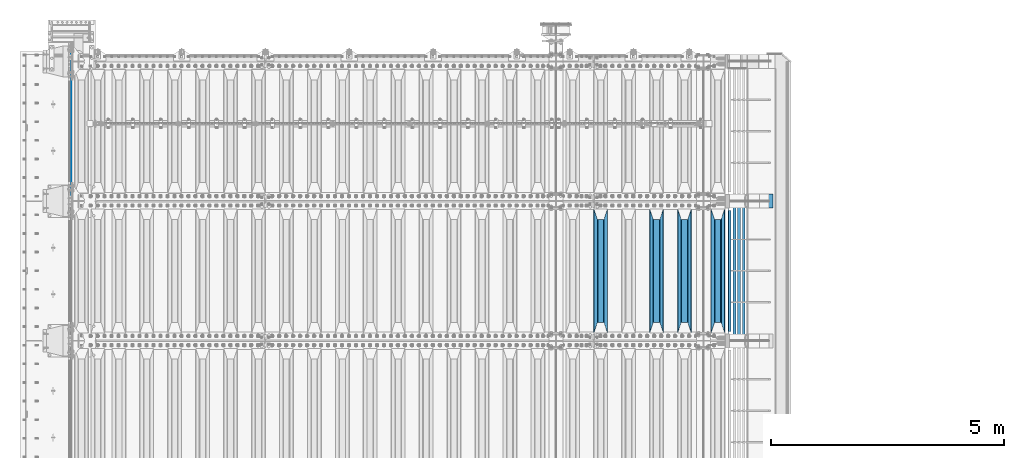
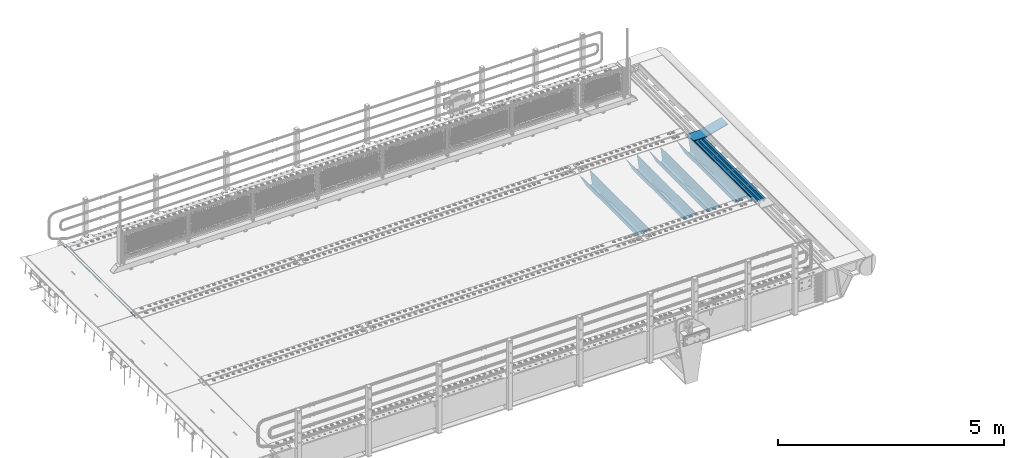
# One storey, part 107 of 219: 10 beams.
"""IFC2X3 building model written with IfcOpenShell, lengths in millimetres."""

from ifc_helpers import new_model, si_unit, frame, origin_with_axes, place, context, subcontext, project, spatial, faceted_brep, material, type_object, element, save


model = new_model("IFC2X3")

# Units and contexts
model_context = context("Model", 3, precision=1e-05, world=origin_with_axes())
body_context = subcontext(model_context, "Body", "Model", "MODEL_VIEW")
ifc_project = project(units=[si_unit("LENGTHUNIT", "METRE", prefix="MILLI"), si_unit("AREAUNIT", "SQUARE_METRE"), si_unit("VOLUMEUNIT", "CUBIC_METRE"), si_unit("MASSUNIT", "GRAM", prefix="KILO"), si_unit("TIMEUNIT", "SECOND"), si_unit("PLANEANGLEUNIT", "RADIAN"), si_unit("SOLIDANGLEUNIT", "STERADIAN"), si_unit("THERMODYNAMICTEMPERATUREUNIT", "DEGREE_CELSIUS"), si_unit("LUMINOUSINTENSITYUNIT", "LUMEN")], contexts=[model_context])

# Site, building, storey
site_placement = place(None, origin_with_axes())
site = spatial("IfcSite", under=ifc_project, at=site_placement, CompositionType="ELEMENT")
building_placement = place(site_placement, origin_with_axes())
building = spatial("IfcBuilding", under=site, at=building_placement, Name="Standard", CompositionType="ELEMENT")
storey_placement = place(building_placement, origin_with_axes())
storey = spatial("IfcBuildingStorey", under=building, at=storey_placement, Name="Undefined", CompositionType="ELEMENT", Elevation=0.0)

# Beams
ifc_material_1 = material(Name="STEEL/S355N")
beam_type_1 = type_object("IfcBeamType", Name="D20", PredefinedType="NOTDEFINED")
beam_1_placement = place(storey_placement, frame((-35.0, 30004.9999999999, -25.9999999971316), z_axis=(0.0, 0.0, 1.0), x_axis=(0.0, 1.0, 0.0)))
element("IfcBeam", 1, at=beam_1_placement, inside=storey, type_object=beam_type_1, material=ifc_material_1, ObjectType="D20", context=body_context, shape_type="Brep", body=[
    faceted_brep([(0.0, -10.0, 0.0), (0.0, -7.07106781186667, -7.07106781186548), (3145.00000000001, -7.07106781186548, -7.07106781186548), (3145.00000000001, -10.0, 0.0), (0.0, 0.0, -10.0), (3145.00000000001, 0.0, -10.0), (0.0, 7.07106781186667, -7.07106781186548), (3145.00000000001, 7.07106781186548, -7.07106781186547), (0.0, 10.0, 0.0), (3145.00000000001, 10.0, 0.0), (0.0, 7.07106781186667, 7.07106781186548), (3145.00000000001, 7.07106781186548, 7.07106781186548), (0.0, 0.0, 10.0), (3145.00000000001, 0.0, 10.0), (0.0, -7.07106781186667, 7.07106781186548), (3145.00000000001, -7.07106781186548, 7.07106781186548)], [[[0, 1, 2, 3]], [[1, 4, 5, 2]], [[4, 6, 7, 5]], [[6, 8, 9, 7]], [[8, 10, 11, 9]], [[10, 12, 13, 11]], [[12, 14, 15, 13]], [[14, 0, 3, 15]], [[5, 7, 9, 11, 13, 15, 3, 2]], [[14, 12, 10, 8, 6, 4, 1, 0]]]),
])
beam_type_2 = type_object("IfcBeamType", PredefinedType="NOTDEFINED")
beam_2_placement = place(storey_placement, frame((13867.0, 27175.0, -115.0), z_axis=(0.0, 0.0, 1.0), x_axis=(0.0, 1.0, 0.0)))
element("IfcBeam", 2, at=beam_2_placement, inside=storey, type_object=beam_type_2, material=ifc_material_1, context=body_context, shape_type="Brep", body=[
    faceted_brep([(0.0, 150.0, 115.0), (0.0, 143.690000000001, 115.0), (2650.00000000297, 143.690000000001, 115.0), (2650.00000000297, 150.0, 115.0), (2650.00000000297, 142.0595652184, 110.000000003094), (2650.00000000297, 148.3695652184, 110.000000003094), (2441.90079219209, -80.110360073113, -98.0992078077845), (2437.7588105432, -77.5672621345566, -102.241189456673), (2434.06523489747, -74.4080125315541, -105.934765102404), (2430.9108609509, -70.7102721255742, -109.089139048974), (2428.37322971128, -66.5649389910068, -111.626770288588), (2426.51472138055, -62.0739139532889, -113.485278619323), (2425.38102192092, -57.3475956567672, -114.618978078955), (2424.99999999988, -52.5021667386536, -115.0), (2424.99999999988, 52.5021667386536, -115.0), (2425.38102192092, 57.3475956567672, -114.618978078955), (2426.51472138055, 62.0739139532889, -113.485278619323), (2428.37322971128, 66.5649389910068, -111.626770288588), (2430.9108609509, 70.7102721255742, -109.089139048974), (2434.06523489747, 74.4080125315541, -105.934765102404), (2437.7588105432, 77.5672621345566, -102.241189456673), (2441.90079219209, 80.110360073113, -98.0992078077846), (2446.38936140512, 81.9747917625791, -93.6106385947584), (2448.2494850041, 76.2713538057269, -91.7505149957729), (2444.62967112263, 74.7677798626082, -95.3703288772456), (2441.28936334127, 72.7168944282894, -98.710636658607), (2438.31067330439, 70.1691124903828, -101.689326695487), (2435.76682334748, 67.1870637758839, -104.233176652398), (2433.72034654134, 63.8440531834913, -106.279653458539), (2432.22154950042, 60.2222587982342, -107.778450499454), (2431.30727574265, 56.4107117849107, -108.692724257221), (2430.99999999987, 52.5031078186894, -109.0), (2430.99999999987, -52.5031078186894, -109.0), (2431.30727574265, -56.4107117849107, -108.692724257221), (2432.22154950042, -60.2222587982342, -107.778450499454), (2433.72034654134, -63.8440531834913, -106.279653458539), (2435.76682334748, -67.1870637758839, -104.233176652398), (2438.31067330439, -70.1691124903828, -101.689326695487), (2441.28936334127, -72.7168944282894, -98.7106366586071), (2444.62967112263, -74.7677798626082, -95.3703288772457), (2448.2494850041, -76.2713538057269, -91.7505149957729), (2650.00000000297, -142.0595652184, 110.000000003094), (2650.00000000297, -148.3695652184, 110.000000003094), (2446.38936140512, -81.9747917625791, -93.6106385947584), (2650.00000000297, -143.690000000001, 115.0), (2650.00000000297, -150.0, 115.0), (0.0, -143.690000000001, 115.0), (0.0, -150.0, 115.0), (0.0, -148.369565218261, 110.000000002667), (203.610638597427, -81.9747917625791, -93.6106385947584), (208.09920781045, -80.110360073113, -98.0992078077845), (212.241189459342, -77.5672621345566, -102.241189456673), (215.93476510507, -74.4080125315541, -105.934765102404), (219.089139051641, -70.7102721255742, -109.089139048974), (221.626770291256, -66.5649389910068, -111.626770288588), (223.485278621989, -62.0739139532889, -113.485278619323), (224.618978081624, -57.3475956567672, -114.618978078955), (225.000000002663, -52.5021667386536, -115.0), (225.000000002663, 52.5021667386536, -115.0), (224.618978081624, 57.3475956567672, -114.618978078955), (223.485278621989, 62.0739139532889, -113.485278619323), (221.626770291256, 66.5649389910068, -111.626770288588), (219.089139051641, 70.7102721255742, -109.089139048974), (215.93476510507, 74.4080125315541, -105.934765102404), (212.241189459342, 77.5672621345566, -102.241189456673), (208.09920781045, 80.110360073113, -98.0992078077846), (203.610638597427, 81.9747917625791, -93.6106385947584), (0.0, 148.369565218261, 110.000000002667), (0.0, 142.059565218262, 110.000000002667), (201.750514998439, 76.2713538057269, -91.7505149957729), (205.370328879915, 74.7677798626082, -95.3703288772456), (208.710636661275, 72.7168944282894, -98.710636658607), (211.689326698157, 70.1691124903828, -101.689326695487), (214.233176655063, 67.1870637758839, -104.233176652398), (216.279653461206, 63.8440531834913, -106.279653458539), (217.778450502123, 60.2222587982342, -107.778450499454), (218.69272425989, 56.4107117849107, -108.692724257221), (219.00000000267, 52.5031078186894, -109.0), (219.00000000267, -52.5031078186894, -109.0), (218.69272425989, -56.4107117849107, -108.692724257221), (217.778450502123, -60.2222587982342, -107.778450499454), (216.279653461206, -63.8440531834913, -106.279653458539), (214.233176655063, -67.1870637758839, -104.233176652398), (211.689326698157, -70.1691124903828, -101.689326695487), (208.710636661275, -72.7168944282894, -98.7106366586071), (205.370328879915, -74.7677798626082, -95.3703288772457), (201.750514998439, -76.2713538057269, -91.7505149957729), (0.0, -142.059565218262, 110.000000002667)], [[[0, 1, 2, 3]], [[3, 2, 4, 5]], [[6, 7, 8, 9, 10, 11, 12, 13, 14, 15, 16, 17, 18, 19, 20, 21, 22, 5, 4, 23, 24, 25, 26, 27, 28, 29, 30, 31, 32, 33, 34, 35, 36, 37, 38, 39, 40, 41, 42, 43]], [[44, 45, 42, 41]], [[46, 47, 45, 44]], [[43, 42, 45, 47, 48, 49]], [[6, 43, 49, 50]], [[7, 6, 50, 51]], [[8, 7, 51, 52]], [[9, 8, 52, 53]], [[10, 9, 53, 54]], [[11, 10, 54, 55]], [[12, 11, 55, 56]], [[13, 12, 56, 57]], [[14, 13, 57, 58]], [[15, 14, 58, 59]], [[16, 15, 59, 60]], [[17, 16, 60, 61]], [[18, 17, 61, 62]], [[19, 18, 62, 63]], [[20, 19, 63, 64]], [[21, 20, 64, 65]], [[22, 21, 65, 66]], [[0, 3, 5, 22, 66, 67]], [[1, 0, 67, 68]], [[23, 4, 2, 1, 68, 69]], [[24, 23, 69, 70]], [[25, 24, 70, 71]], [[26, 25, 71, 72]], [[27, 26, 72, 73]], [[28, 27, 73, 74]], [[29, 28, 74, 75]], [[30, 29, 75, 76]], [[31, 30, 76, 77]], [[32, 31, 77, 78]], [[33, 32, 78, 79]], [[34, 33, 79, 80]], [[35, 34, 80, 81]], [[36, 35, 81, 82]], [[37, 36, 82, 83]], [[38, 37, 83, 84]], [[39, 38, 84, 85]], [[40, 39, 85, 86]], [[46, 44, 41, 40, 86, 87]], [[47, 46, 87, 48]], [[86, 85, 84, 83, 82, 81, 80, 79, 78, 77, 76, 75, 74, 73, 72, 71, 70, 69, 68, 67, 66, 65, 64, 63, 62, 61, 60, 59, 58, 57, 56, 55, 54, 53, 52, 51, 50, 49, 48, 87]]]),
])
beam_3_placement = place(storey_placement, frame((13150.0, 27175.0, -115.0), z_axis=(0.0, 0.0, 1.0), x_axis=(0.0, 1.0, 0.0)))
element("IfcBeam", 3, at=beam_3_placement, inside=storey, type_object=beam_type_2, material=ifc_material_1, context=body_context, shape_type="Brep", body=[
    faceted_brep([(0.0, 150.0, 115.0), (0.0, 143.690000000001, 115.0), (2650.00000000297, 143.690000000001, 115.0), (2650.00000000297, 150.0, 115.0), (2650.00000000297, 142.0595652184, 110.000000003094), (2650.00000000297, 148.3695652184, 110.000000003094), (2441.90079219209, -80.110360073113, -98.0992078077845), (2437.7588105432, -77.5672621345566, -102.241189456673), (2434.06523489747, -74.4080125315541, -105.934765102404), (2430.9108609509, -70.7102721255742, -109.089139048974), (2428.37322971128, -66.5649389910068, -111.626770288588), (2426.51472138055, -62.0739139532889, -113.485278619323), (2425.38102192092, -57.3475956567672, -114.618978078955), (2424.99999999988, -52.5021667386536, -115.0), (2424.99999999988, 52.5021667386536, -115.0), (2425.38102192092, 57.3475956567672, -114.618978078955), (2426.51472138055, 62.0739139532889, -113.485278619323), (2428.37322971128, 66.5649389910068, -111.626770288588), (2430.9108609509, 70.7102721255742, -109.089139048974), (2434.06523489747, 74.4080125315541, -105.934765102404), (2437.7588105432, 77.5672621345566, -102.241189456673), (2441.90079219209, 80.110360073113, -98.0992078077846), (2446.38936140512, 81.9747917625791, -93.6106385947584), (2448.2494850041, 76.2713538057269, -91.7505149957729), (2444.62967112263, 74.7677798626082, -95.3703288772456), (2441.28936334127, 72.7168944282894, -98.710636658607), (2438.31067330439, 70.1691124903828, -101.689326695487), (2435.76682334748, 67.1870637758839, -104.233176652398), (2433.72034654134, 63.8440531834913, -106.279653458539), (2432.22154950042, 60.2222587982342, -107.778450499454), (2431.30727574265, 56.4107117849107, -108.692724257221), (2430.99999999987, 52.5031078186894, -109.0), (2430.99999999987, -52.5031078186894, -109.0), (2431.30727574265, -56.4107117849107, -108.692724257221), (2432.22154950042, -60.2222587982342, -107.778450499454), (2433.72034654134, -63.8440531834913, -106.279653458539), (2435.76682334748, -67.1870637758839, -104.233176652398), (2438.31067330439, -70.1691124903828, -101.689326695487), (2441.28936334127, -72.7168944282894, -98.7106366586071), (2444.62967112263, -74.7677798626082, -95.3703288772457), (2448.2494850041, -76.2713538057269, -91.7505149957729), (2650.00000000297, -142.0595652184, 110.000000003094), (2650.00000000297, -148.3695652184, 110.000000003094), (2446.38936140512, -81.9747917625791, -93.6106385947584), (2650.00000000297, -143.690000000001, 115.0), (2650.00000000297, -150.0, 115.0), (0.0, -143.690000000001, 115.0), (0.0, -150.0, 115.0), (0.0, -148.369565218261, 110.000000002667), (203.610638597427, -81.9747917625791, -93.6106385947584), (208.09920781045, -80.110360073113, -98.0992078077845), (212.241189459342, -77.5672621345566, -102.241189456673), (215.93476510507, -74.4080125315541, -105.934765102404), (219.089139051641, -70.7102721255742, -109.089139048974), (221.626770291256, -66.5649389910068, -111.626770288588), (223.485278621989, -62.0739139532889, -113.485278619323), (224.618978081624, -57.3475956567672, -114.618978078955), (225.000000002663, -52.5021667386536, -115.0), (225.000000002663, 52.5021667386536, -115.0), (224.618978081624, 57.3475956567672, -114.618978078955), (223.485278621989, 62.0739139532889, -113.485278619323), (221.626770291256, 66.5649389910068, -111.626770288588), (219.089139051641, 70.7102721255742, -109.089139048974), (215.93476510507, 74.4080125315541, -105.934765102404), (212.241189459342, 77.5672621345566, -102.241189456673), (208.09920781045, 80.110360073113, -98.0992078077846), (203.610638597427, 81.9747917625791, -93.6106385947584), (0.0, 148.369565218261, 110.000000002667), (0.0, 142.059565218262, 110.000000002667), (201.750514998439, 76.2713538057269, -91.7505149957729), (205.370328879915, 74.7677798626082, -95.3703288772456), (208.710636661275, 72.7168944282894, -98.710636658607), (211.689326698157, 70.1691124903828, -101.689326695487), (214.233176655063, 67.1870637758839, -104.233176652398), (216.279653461206, 63.8440531834913, -106.279653458539), (217.778450502123, 60.2222587982342, -107.778450499454), (218.69272425989, 56.4107117849107, -108.692724257221), (219.00000000267, 52.5031078186894, -109.0), (219.00000000267, -52.5031078186894, -109.0), (218.69272425989, -56.4107117849107, -108.692724257221), (217.778450502123, -60.2222587982342, -107.778450499454), (216.279653461206, -63.8440531834913, -106.279653458539), (214.233176655063, -67.1870637758839, -104.233176652398), (211.689326698157, -70.1691124903828, -101.689326695487), (208.710636661275, -72.7168944282894, -98.7106366586071), (205.370328879915, -74.7677798626082, -95.3703288772457), (201.750514998439, -76.2713538057269, -91.7505149957729), (0.0, -142.059565218262, 110.000000002667)], [[[0, 1, 2, 3]], [[3, 2, 4, 5]], [[6, 7, 8, 9, 10, 11, 12, 13, 14, 15, 16, 17, 18, 19, 20, 21, 22, 5, 4, 23, 24, 25, 26, 27, 28, 29, 30, 31, 32, 33, 34, 35, 36, 37, 38, 39, 40, 41, 42, 43]], [[44, 45, 42, 41]], [[46, 47, 45, 44]], [[43, 42, 45, 47, 48, 49]], [[6, 43, 49, 50]], [[7, 6, 50, 51]], [[8, 7, 51, 52]], [[9, 8, 52, 53]], [[10, 9, 53, 54]], [[11, 10, 54, 55]], [[12, 11, 55, 56]], [[13, 12, 56, 57]], [[14, 13, 57, 58]], [[15, 14, 58, 59]], [[16, 15, 59, 60]], [[17, 16, 60, 61]], [[18, 17, 61, 62]], [[19, 18, 62, 63]], [[20, 19, 63, 64]], [[21, 20, 64, 65]], [[22, 21, 65, 66]], [[0, 3, 5, 22, 66, 67]], [[1, 0, 67, 68]], [[23, 4, 2, 1, 68, 69]], [[24, 23, 69, 70]], [[25, 24, 70, 71]], [[26, 25, 71, 72]], [[27, 26, 72, 73]], [[28, 27, 73, 74]], [[29, 28, 74, 75]], [[30, 29, 75, 76]], [[31, 30, 76, 77]], [[32, 31, 77, 78]], [[33, 32, 78, 79]], [[34, 33, 79, 80]], [[35, 34, 80, 81]], [[36, 35, 81, 82]], [[37, 36, 82, 83]], [[38, 37, 83, 84]], [[39, 38, 84, 85]], [[40, 39, 85, 86]], [[46, 44, 41, 40, 86, 87]], [[47, 46, 87, 48]], [[86, 85, 84, 83, 82, 81, 80, 79, 78, 77, 76, 75, 74, 73, 72, 71, 70, 69, 68, 67, 66, 65, 64, 63, 62, 61, 60, 59, 58, 57, 56, 55, 54, 53, 52, 51, 50, 49, 48, 87]]]),
])
beam_4_placement = place(storey_placement, frame((12550.0, 27175.0, -115.0), z_axis=(0.0, 0.0, 1.0), x_axis=(0.0, 1.0, 0.0)))
element("IfcBeam", 4, at=beam_4_placement, inside=storey, type_object=beam_type_2, material=ifc_material_1, context=body_context, shape_type="Brep", body=[
    faceted_brep([(0.0, 150.0, 115.0), (0.0, 143.690000000001, 115.0), (2650.00000000297, 143.690000000001, 115.0), (2650.00000000297, 150.0, 115.0), (2650.00000000297, 142.0595652184, 110.000000003094), (2650.00000000297, 148.3695652184, 110.000000003094), (2441.90079219209, -80.110360073113, -98.0992078077845), (2437.7588105432, -77.5672621345566, -102.241189456673), (2434.06523489747, -74.4080125315541, -105.934765102404), (2430.9108609509, -70.7102721255742, -109.089139048974), (2428.37322971128, -66.5649389910068, -111.626770288588), (2426.51472138055, -62.0739139532889, -113.485278619323), (2425.38102192092, -57.3475956567672, -114.618978078955), (2424.99999999988, -52.5021667386536, -115.0), (2424.99999999988, 52.5021667386536, -115.0), (2425.38102192092, 57.3475956567672, -114.618978078955), (2426.51472138055, 62.0739139532889, -113.485278619323), (2428.37322971128, 66.5649389910068, -111.626770288588), (2430.9108609509, 70.7102721255742, -109.089139048974), (2434.06523489747, 74.4080125315541, -105.934765102404), (2437.7588105432, 77.5672621345566, -102.241189456673), (2441.90079219209, 80.110360073113, -98.0992078077846), (2446.38936140512, 81.9747917625791, -93.6106385947584), (2448.2494850041, 76.2713538057269, -91.7505149957729), (2444.62967112263, 74.7677798626082, -95.3703288772456), (2441.28936334127, 72.7168944282894, -98.710636658607), (2438.31067330439, 70.1691124903828, -101.689326695487), (2435.76682334748, 67.1870637758839, -104.233176652398), (2433.72034654134, 63.8440531834913, -106.279653458539), (2432.22154950042, 60.2222587982342, -107.778450499454), (2431.30727574265, 56.4107117849107, -108.692724257221), (2430.99999999987, 52.5031078186894, -109.0), (2430.99999999987, -52.5031078186894, -109.0), (2431.30727574265, -56.4107117849107, -108.692724257221), (2432.22154950042, -60.2222587982342, -107.778450499454), (2433.72034654134, -63.8440531834913, -106.279653458539), (2435.76682334748, -67.1870637758839, -104.233176652398), (2438.31067330439, -70.1691124903828, -101.689326695487), (2441.28936334127, -72.7168944282894, -98.7106366586071), (2444.62967112263, -74.7677798626082, -95.3703288772457), (2448.2494850041, -76.2713538057269, -91.7505149957729), (2650.00000000297, -142.0595652184, 110.000000003094), (2650.00000000297, -148.3695652184, 110.000000003094), (2446.38936140512, -81.9747917625791, -93.6106385947584), (2650.00000000297, -143.690000000001, 115.0), (2650.00000000297, -150.0, 115.0), (0.0, -143.690000000001, 115.0), (0.0, -150.0, 115.0), (0.0, -148.369565218261, 110.000000002667), (203.610638597427, -81.9747917625791, -93.6106385947584), (208.09920781045, -80.110360073113, -98.0992078077845), (212.241189459342, -77.5672621345566, -102.241189456673), (215.93476510507, -74.4080125315541, -105.934765102404), (219.089139051641, -70.7102721255742, -109.089139048974), (221.626770291256, -66.5649389910068, -111.626770288588), (223.485278621989, -62.0739139532889, -113.485278619323), (224.618978081624, -57.3475956567672, -114.618978078955), (225.000000002663, -52.5021667386536, -115.0), (225.000000002663, 52.5021667386536, -115.0), (224.618978081624, 57.3475956567672, -114.618978078955), (223.485278621989, 62.0739139532889, -113.485278619323), (221.626770291256, 66.5649389910068, -111.626770288588), (219.089139051641, 70.7102721255742, -109.089139048974), (215.93476510507, 74.4080125315541, -105.934765102404), (212.241189459342, 77.5672621345566, -102.241189456673), (208.09920781045, 80.110360073113, -98.0992078077846), (203.610638597427, 81.9747917625791, -93.6106385947584), (0.0, 148.369565218261, 110.000000002667), (0.0, 142.059565218262, 110.000000002667), (201.750514998439, 76.2713538057269, -91.7505149957729), (205.370328879915, 74.7677798626082, -95.3703288772456), (208.710636661275, 72.7168944282894, -98.710636658607), (211.689326698157, 70.1691124903828, -101.689326695487), (214.233176655063, 67.1870637758839, -104.233176652398), (216.279653461206, 63.8440531834913, -106.279653458539), (217.778450502123, 60.2222587982342, -107.778450499454), (218.69272425989, 56.4107117849107, -108.692724257221), (219.00000000267, 52.5031078186894, -109.0), (219.00000000267, -52.5031078186894, -109.0), (218.69272425989, -56.4107117849107, -108.692724257221), (217.778450502123, -60.2222587982342, -107.778450499454), (216.279653461206, -63.8440531834913, -106.279653458539), (214.233176655063, -67.1870637758839, -104.233176652398), (211.689326698157, -70.1691124903828, -101.689326695487), (208.710636661275, -72.7168944282894, -98.7106366586071), (205.370328879915, -74.7677798626082, -95.3703288772457), (201.750514998439, -76.2713538057269, -91.7505149957729), (0.0, -142.059565218262, 110.000000002667)], [[[0, 1, 2, 3]], [[3, 2, 4, 5]], [[6, 7, 8, 9, 10, 11, 12, 13, 14, 15, 16, 17, 18, 19, 20, 21, 22, 5, 4, 23, 24, 25, 26, 27, 28, 29, 30, 31, 32, 33, 34, 35, 36, 37, 38, 39, 40, 41, 42, 43]], [[44, 45, 42, 41]], [[46, 47, 45, 44]], [[43, 42, 45, 47, 48, 49]], [[6, 43, 49, 50]], [[7, 6, 50, 51]], [[8, 7, 51, 52]], [[9, 8, 52, 53]], [[10, 9, 53, 54]], [[11, 10, 54, 55]], [[12, 11, 55, 56]], [[13, 12, 56, 57]], [[14, 13, 57, 58]], [[15, 14, 58, 59]], [[16, 15, 59, 60]], [[17, 16, 60, 61]], [[18, 17, 61, 62]], [[19, 18, 62, 63]], [[20, 19, 63, 64]], [[21, 20, 64, 65]], [[22, 21, 65, 66]], [[0, 3, 5, 22, 66, 67]], [[1, 0, 67, 68]], [[23, 4, 2, 1, 68, 69]], [[24, 23, 69, 70]], [[25, 24, 70, 71]], [[26, 25, 71, 72]], [[27, 26, 72, 73]], [[28, 27, 73, 74]], [[29, 28, 74, 75]], [[30, 29, 75, 76]], [[31, 30, 76, 77]], [[32, 31, 77, 78]], [[33, 32, 78, 79]], [[34, 33, 79, 80]], [[35, 34, 80, 81]], [[36, 35, 81, 82]], [[37, 36, 82, 83]], [[38, 37, 83, 84]], [[39, 38, 84, 85]], [[40, 39, 85, 86]], [[46, 44, 41, 40, 86, 87]], [[47, 46, 87, 48]], [[86, 85, 84, 83, 82, 81, 80, 79, 78, 77, 76, 75, 74, 73, 72, 71, 70, 69, 68, 67, 66, 65, 64, 63, 62, 61, 60, 59, 58, 57, 56, 55, 54, 53, 52, 51, 50, 49, 48, 87]]]),
])
beam_5_placement = place(storey_placement, frame((11350.0, 27175.0, -115.0), z_axis=(0.0, 0.0, 1.0), x_axis=(0.0, 1.0, 0.0)))
element("IfcBeam", 5, at=beam_5_placement, inside=storey, type_object=beam_type_2, material=ifc_material_1, context=body_context, shape_type="Brep", body=[
    faceted_brep([(0.0, 150.0, 115.0), (0.0, 143.690000000001, 115.0), (2650.00000000297, 143.690000000001, 115.0), (2650.00000000297, 150.0, 115.0), (2650.00000000297, 142.0595652184, 110.000000003094), (2650.00000000297, 148.3695652184, 110.000000003094), (2441.90079219209, -80.110360073113, -98.0992078077845), (2437.7588105432, -77.5672621345566, -102.241189456673), (2434.06523489747, -74.4080125315541, -105.934765102404), (2430.9108609509, -70.7102721255742, -109.089139048974), (2428.37322971128, -66.5649389910068, -111.626770288588), (2426.51472138055, -62.0739139532889, -113.485278619323), (2425.38102192092, -57.3475956567672, -114.618978078955), (2424.99999999988, -52.5021667386536, -115.0), (2424.99999999988, 52.5021667386536, -115.0), (2425.38102192092, 57.3475956567672, -114.618978078955), (2426.51472138055, 62.0739139532889, -113.485278619323), (2428.37322971128, 66.5649389910068, -111.626770288588), (2430.9108609509, 70.7102721255742, -109.089139048974), (2434.06523489747, 74.4080125315541, -105.934765102404), (2437.7588105432, 77.5672621345566, -102.241189456673), (2441.90079219209, 80.110360073113, -98.0992078077846), (2446.38936140512, 81.9747917625791, -93.6106385947584), (2448.2494850041, 76.2713538057269, -91.7505149957729), (2444.62967112263, 74.7677798626082, -95.3703288772456), (2441.28936334127, 72.7168944282894, -98.710636658607), (2438.31067330439, 70.1691124903828, -101.689326695487), (2435.76682334748, 67.1870637758839, -104.233176652398), (2433.72034654134, 63.8440531834913, -106.279653458539), (2432.22154950042, 60.2222587982342, -107.778450499454), (2431.30727574265, 56.4107117849107, -108.692724257221), (2430.99999999987, 52.5031078186894, -109.0), (2430.99999999987, -52.5031078186894, -109.0), (2431.30727574265, -56.4107117849107, -108.692724257221), (2432.22154950042, -60.2222587982342, -107.778450499454), (2433.72034654134, -63.8440531834913, -106.279653458539), (2435.76682334748, -67.1870637758839, -104.233176652398), (2438.31067330439, -70.1691124903828, -101.689326695487), (2441.28936334127, -72.7168944282894, -98.7106366586071), (2444.62967112263, -74.7677798626082, -95.3703288772457), (2448.2494850041, -76.2713538057269, -91.7505149957729), (2650.00000000297, -142.0595652184, 110.000000003094), (2650.00000000297, -148.3695652184, 110.000000003094), (2446.38936140512, -81.9747917625791, -93.6106385947584), (2650.00000000297, -143.690000000001, 115.0), (2650.00000000297, -150.0, 115.0), (0.0, -143.690000000001, 115.0), (0.0, -150.0, 115.0), (0.0, -148.369565218261, 110.000000002667), (203.610638597427, -81.9747917625791, -93.6106385947584), (208.09920781045, -80.110360073113, -98.0992078077845), (212.241189459342, -77.5672621345566, -102.241189456673), (215.93476510507, -74.4080125315541, -105.934765102404), (219.089139051641, -70.7102721255742, -109.089139048974), (221.626770291256, -66.5649389910068, -111.626770288588), (223.485278621989, -62.0739139532889, -113.485278619323), (224.618978081624, -57.3475956567672, -114.618978078955), (225.000000002663, -52.5021667386536, -115.0), (225.000000002663, 52.5021667386536, -115.0), (224.618978081624, 57.3475956567672, -114.618978078955), (223.485278621989, 62.0739139532889, -113.485278619323), (221.626770291256, 66.5649389910068, -111.626770288588), (219.089139051641, 70.7102721255742, -109.089139048974), (215.93476510507, 74.4080125315541, -105.934765102404), (212.241189459342, 77.5672621345566, -102.241189456673), (208.09920781045, 80.110360073113, -98.0992078077846), (203.610638597427, 81.9747917625791, -93.6106385947584), (0.0, 148.369565218261, 110.000000002667), (0.0, 142.059565218262, 110.000000002667), (201.750514998439, 76.2713538057269, -91.7505149957729), (205.370328879915, 74.7677798626082, -95.3703288772456), (208.710636661275, 72.7168944282894, -98.710636658607), (211.689326698157, 70.1691124903828, -101.689326695487), (214.233176655063, 67.1870637758839, -104.233176652398), (216.279653461206, 63.8440531834913, -106.279653458539), (217.778450502123, 60.2222587982342, -107.778450499454), (218.69272425989, 56.4107117849107, -108.692724257221), (219.00000000267, 52.5031078186894, -109.0), (219.00000000267, -52.5031078186894, -109.0), (218.69272425989, -56.4107117849107, -108.692724257221), (217.778450502123, -60.2222587982342, -107.778450499454), (216.279653461206, -63.8440531834913, -106.279653458539), (214.233176655063, -67.1870637758839, -104.233176652398), (211.689326698157, -70.1691124903828, -101.689326695487), (208.710636661275, -72.7168944282894, -98.7106366586071), (205.370328879915, -74.7677798626082, -95.3703288772457), (201.750514998439, -76.2713538057269, -91.7505149957729), (0.0, -142.059565218262, 110.000000002667)], [[[0, 1, 2, 3]], [[3, 2, 4, 5]], [[6, 7, 8, 9, 10, 11, 12, 13, 14, 15, 16, 17, 18, 19, 20, 21, 22, 5, 4, 23, 24, 25, 26, 27, 28, 29, 30, 31, 32, 33, 34, 35, 36, 37, 38, 39, 40, 41, 42, 43]], [[44, 45, 42, 41]], [[46, 47, 45, 44]], [[43, 42, 45, 47, 48, 49]], [[6, 43, 49, 50]], [[7, 6, 50, 51]], [[8, 7, 51, 52]], [[9, 8, 52, 53]], [[10, 9, 53, 54]], [[11, 10, 54, 55]], [[12, 11, 55, 56]], [[13, 12, 56, 57]], [[14, 13, 57, 58]], [[15, 14, 58, 59]], [[16, 15, 59, 60]], [[17, 16, 60, 61]], [[18, 17, 61, 62]], [[19, 18, 62, 63]], [[20, 19, 63, 64]], [[21, 20, 64, 65]], [[22, 21, 65, 66]], [[0, 3, 5, 22, 66, 67]], [[1, 0, 67, 68]], [[23, 4, 2, 1, 68, 69]], [[24, 23, 69, 70]], [[25, 24, 70, 71]], [[26, 25, 71, 72]], [[27, 26, 72, 73]], [[28, 27, 73, 74]], [[29, 28, 74, 75]], [[30, 29, 75, 76]], [[31, 30, 76, 77]], [[32, 31, 77, 78]], [[33, 32, 78, 79]], [[34, 33, 79, 80]], [[35, 34, 80, 81]], [[36, 35, 81, 82]], [[37, 36, 82, 83]], [[38, 37, 83, 84]], [[39, 38, 84, 85]], [[40, 39, 85, 86]], [[46, 44, 41, 40, 86, 87]], [[47, 46, 87, 48]], [[86, 85, 84, 83, 82, 81, 80, 79, 78, 77, 76, 75, 74, 73, 72, 71, 70, 69, 68, 67, 66, 65, 64, 63, 62, 61, 60, 59, 58, 57, 56, 55, 54, 53, 52, 51, 50, 49, 48, 87]]]),
])
ifc_material_2 = material(Name="STEEL/S355J2")
beam_type_3 = type_object("IfcBeamType", PredefinedType="NOTDEFINED")
beam_6_placement = place(storey_placement, frame((14114.5025260065, 27150.0, -124.999999999985), z_axis=(0.0, 0.0, 1.0), x_axis=(0.0, 1.0, 0.0)))
element("IfcBeam", 6, at=beam_6_placement, inside=storey, type_object=beam_type_3, material=ifc_material_2, context=body_context, shape_type="Brep", body=[
    faceted_brep([(2700.0, 22.5, -15.0), (2684.54915028125, 22.5000000000018, -17.4471741852423), (2684.54915028125, 32.5, -17.4471741852423), (2700.0, 32.5, -15.0), (2670.61073738538, 22.5000000000018, -24.5491502812526), (2670.61073738538, 32.5, -24.5491502812526), (2659.54915028125, 22.5000000000018, -35.6107373853764), (2659.54915028125, 32.5, -35.6107373853764), (2652.44717418524, 22.5000000000018, -49.5491502812526), (2652.44717418524, 32.5, -49.5491502812526), (2651.58384440325, -32.5, -55.0), (2650.0, -32.5, -65.0), (2650.0, 32.5, -65.0), (2651.58384440325, 22.5, -55.0), (0.0, 32.5, 65.0), (0.0, 22.5, 65.0), (2700.0, 22.5, 65.0), (2700.0, 32.5, 65.0), (0.0, 32.5, -15.0), (0.0, 22.5, -15.0), (15.4508497187489, 32.5, -17.4471741852423), (15.4508497187489, 22.5, -17.4471741852423), (29.3892626146226, 32.5, -24.5491502812526), (29.3892626146226, 22.5, -24.5491502812526), (40.4508497187489, 32.5, -35.6107373853763), (40.4508497187489, 22.5, -35.6107373853763), (47.5528258147569, 32.5, -49.5491502812526), (47.5528258147569, 22.5, -49.5491502812526), (50.0, -32.5, -65.0), (48.4161555967512, -32.5, -55.0), (48.4161555967512, 22.5, -55.0), (50.0, 32.5, -65.0)], [[[0, 1, 2, 3]], [[4, 5, 2, 1]], [[6, 7, 5, 4]], [[8, 9, 7, 6]], [[10, 11, 12, 9, 8, 13]], [[14, 15, 16, 17]], [[15, 14, 18, 19]], [[19, 18, 20, 21]], [[21, 20, 22, 23]], [[23, 22, 24, 25]], [[25, 24, 26, 27]], [[28, 29, 30, 27, 26, 31]], [[30, 29, 10, 13]], [[16, 15, 19, 21, 23, 25, 27, 30, 13, 8, 6, 4, 1, 0]], [[17, 16, 0, 3]], [[5, 7, 9, 12, 31, 26, 24, 22, 20, 18, 14, 17, 3, 2]], [[28, 31, 12, 11]], [[29, 28, 11, 10]]]),
])
beam_type_4 = type_object("IfcBeamType", PredefinedType="NOTDEFINED")
beam_7_placement = place(storey_placement, frame((14106.9988298906, 30000.0, -169.999999999995), z_axis=(0.0, -1.0, 0.0), x_axis=(1.0, 0.0, 0.0)))
element("IfcBeam", 7, at=beam_7_placement, inside=storey, type_object=beam_type_4, material=ifc_material_1, context=body_context, shape_type="Brep", body=[
    faceted_brep([(0.0, 10.0, -150.0), (0.0, 10.0, 150.0), (356.495387467725, 10.0, 150.0), (356.495387467727, 9.99999999999903, -150.0), (0.0, -10.0, 150.0), (0.0, -10.0, -150.0), (356.495387467725, -10.0, -150.0), (356.495387467725, -10.0, 150.0), (382.770279632496, 11.7334369044542, 150.0), (382.770279632496, 11.7334369044542, -150.0), (385.397768848972, -8.0932194051, -150.0), (385.397768848972, -8.0932194051, 150.0), (413.799145685096, -2.40593045896915, -150.0), (413.799145685096, -2.40593045896915, 150.0), (408.589713119878, 16.9036995827554, 150.0), (408.589713119874, 16.9036995827009, -150.0), (938.999999999996, 160.0, 150.0), (938.999999999996, 160.0, -150.0), (944.209432565211, 140.69036995827, 150.0), (944.209432565211, 140.69036995827, -150.0)], [[[0, 1, 2, 3]], [[4, 5, 6, 7]], [[5, 4, 1, 0]], [[3, 2, 8, 9]], [[7, 6, 10, 11]], [[10, 12, 13, 11]], [[8, 14, 15, 9]], [[15, 14, 16, 17]], [[14, 8, 2, 1, 4, 7, 11, 13, 18, 16]], [[13, 12, 19, 18]], [[12, 10, 6, 5, 0, 3, 9, 15, 17, 19]], [[18, 19, 17, 16]]]),
])
beam_type_5 = type_object("IfcBeamType", PredefinedType="NOTDEFINED")
for number, where, z_axis, x_axis in (
    (8, (14422.0025260169, 29869.9999003886, -209.999999999563), (0.0, 0.0, -1.0), (0.0, -1.0, 0.0)),
    (9, (14322.0025260169, 29869.9999003886, -209.999999999563), (0.0, 0.0, -1.0), (0.0, -1.0, 0.0)),
    (10, (14222.0025260162, 29870.0000023132, -209.999999999622), (0.0, 0.0, -1.0), (0.0, -1.0, 0.0)),
):
    element("IfcBeam", number, at=place(storey_placement, frame(where, z_axis=z_axis, x_axis=x_axis)), inside=storey, type_object=beam_type_5, material=ifc_material_2, context=body_context, shape_type="Brep", body=[
        faceted_brep([(3.63797880709171e-12, 29.9999999999982, -30.0), (0.0, 29.9999999999982, 30.0), (2740.00017042501, 29.9999999999982, 30.0000000000001), (2740.00017042501, 29.9999999999982, -29.9999999999999), (0.0, 23.9999999999982, 30.0), (2740.00017042501, 23.9999999999982, 30.0), (0.0, 23.9999999999982, -24.0), (2740.00017042501, 23.9999999999982, -24.0), (3.63797880709171e-12, -30.0000000000018, -24.0), (2740.00017042501, -30.0000000000018, -24.0), (3.63797880709171e-12, -30.0000000000018, -30.0), (2740.00017042501, -30.0000000000018, -30.0)], [[[0, 1, 2, 3]], [[1, 4, 5, 2]], [[4, 6, 7, 5]], [[6, 8, 9, 7]], [[8, 10, 11, 9]], [[10, 0, 3, 11]], [[5, 7, 9, 11, 3, 2]], [[10, 8, 6, 4, 1, 0]]]),
    ])

save(model, "model.ifc")
